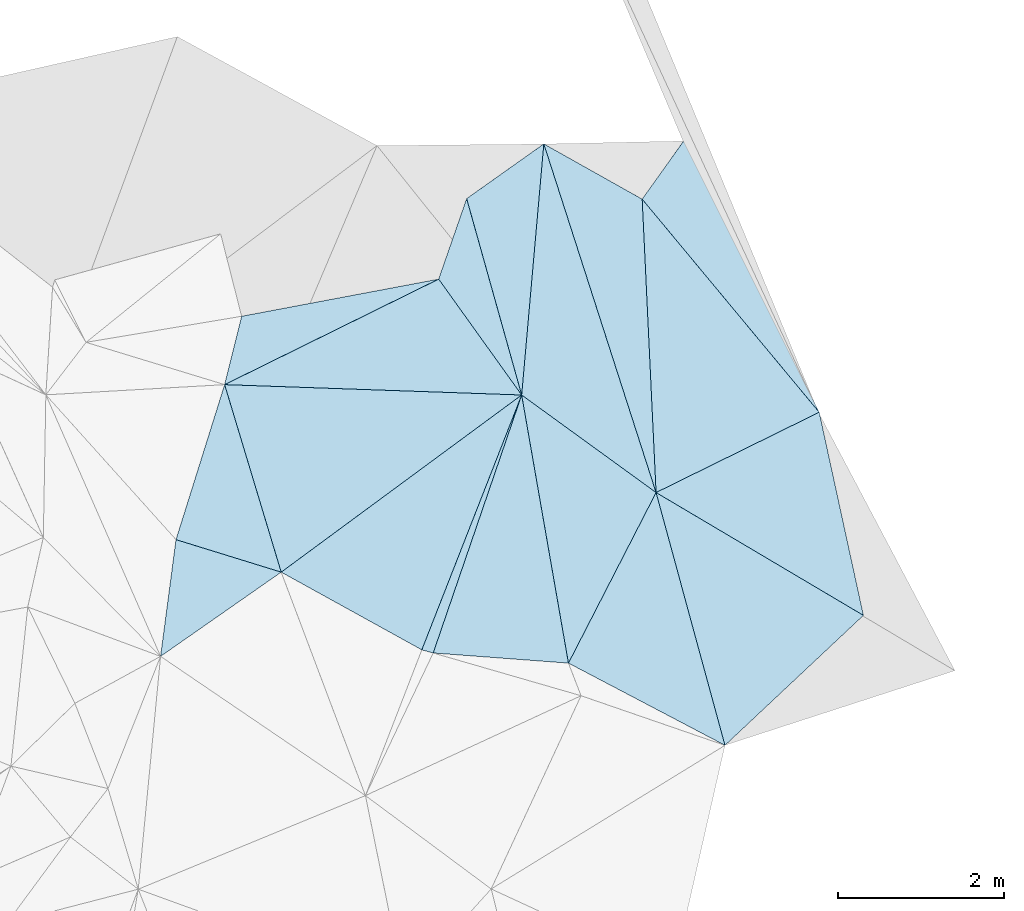
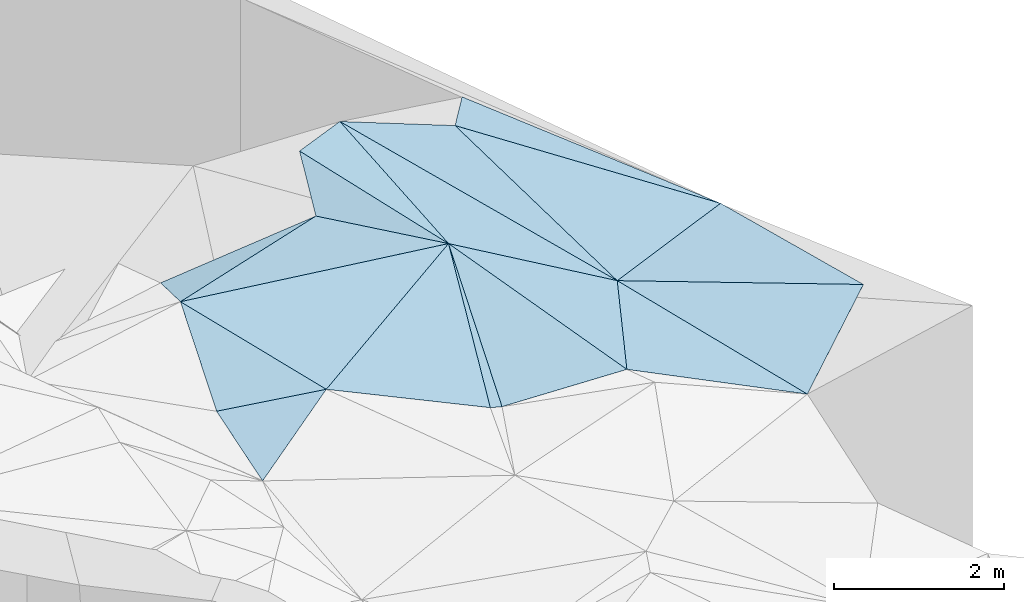
# One storey, part 163 of 275: 18 plates.
"""IFC2X3 building model written with IfcOpenShell, lengths in millimetres."""

from ifc_helpers import new_model, si_unit, frame, origin_with_axes, place, context, subcontext, project, spatial, polyline, outline, extrude, material, type_object, element, save


model = new_model("IFC2X3")

# Units and contexts
model_context = context("Model", 3, precision=1e-05, world=origin_with_axes())
body_context = subcontext(model_context, "Body", "Model", "MODEL_VIEW")
ifc_project = project(units=[si_unit("LENGTHUNIT", "METRE", prefix="MILLI"), si_unit("AREAUNIT", "SQUARE_METRE"), si_unit("VOLUMEUNIT", "CUBIC_METRE"), si_unit("MASSUNIT", "GRAM", prefix="KILO"), si_unit("TIMEUNIT", "SECOND"), si_unit("PLANEANGLEUNIT", "RADIAN"), si_unit("SOLIDANGLEUNIT", "STERADIAN"), si_unit("THERMODYNAMICTEMPERATUREUNIT", "DEGREE_CELSIUS"), si_unit("LUMINOUSINTENSITYUNIT", "LUMEN")], contexts=[model_context])

# Site, building, storey
site_placement = place(None, origin_with_axes())
site = spatial("IfcSite", under=ifc_project, at=site_placement, CompositionType="ELEMENT")
building_placement = place(site_placement, origin_with_axes())
building = spatial("IfcBuilding", under=site, at=building_placement, Name="Undefined", CompositionType="ELEMENT")
storey_placement = place(building_placement, origin_with_axes())
storey = spatial("IfcBuildingStorey", under=building, at=storey_placement, Name="Undefined", CompositionType="ELEMENT", Elevation=0.0)

# Plates
ifc_material = material()
plate_type_1 = type_object("IfcPlateType", PredefinedType="NOTDEFINED")
plate_1_placement = place(storey_placement, frame((-32198.8516801343, 135971.552970528, 45569.5074828096), z_axis=(-0.098591754816922, -0.141244502335463, -0.985053123664976), x_axis=(0.581396196965825, -0.811538201733318, 0.0581739570695312)))
element("IfcPlate", 1, at=plate_1_placement, inside=storey, type_object=plate_type_1, material=ifc_material, Name="00", context=body_context, shape_type="SweptSolid", body=[
    extrude(outline(polyline([(0.0, 0.0), (1718.98229980469, 9.60426405072212e-09), (-441.482147216797, 2872.2802734375), (0.0, 0.0)])), frame((-8.85201319254618e-08, 2.18876761149539e-07, -0.5000001331573), z_axis=(0.0, 0.0, 1.0), x_axis=(1.0, 0.0, 0.0)), (0.0, 0.0, 1.0), 1.0),
])
plate_type_2 = type_object("IfcPlateType", PredefinedType="NOTDEFINED")
plate_2_placement = place(storey_placement, frame((-31199.5191796899, 134576.589230725, 45669.5165076819), z_axis=(-0.253085129396398, -0.0291850272704862, -0.967003697749719), x_axis=(0.794519000365559, -0.57657067207497, -0.190540856933965)))
element("IfcPlate", 2, at=plate_2_placement, inside=storey, type_object=plate_type_2, material=ifc_material, Name="00", context=body_context, shape_type="SweptSolid", body=[
    extrude(outline(polyline([(0.0, 0.0), (2036.30871582031, -1.00117176771164e-08), (2318.16040039063, 2316.27563476563), (0.0, 0.0)])), frame((-8.85201319254618e-08, 2.18876761149539e-07, -0.5000001331573), z_axis=(0.0, 0.0, 1.0), x_axis=(1.0, 0.0, 0.0)), (0.0, 0.0, 1.0), 1.0),
])
plate_type_3 = type_object("IfcPlateType", PredefinedType="NOTDEFINED")
plate_3_placement = place(storey_placement, frame((-29581.5249611842, 133402.548021027, 45281.5007454787), z_axis=(-0.0365037972661945, 0.0401118083503274, -0.998528174673111), x_axis=(-0.306126815198871, 0.950709092130816, 0.0493821339757117)))
element("IfcPlate", 3, at=plate_3_placement, inside=storey, type_object=plate_type_3, material=ifc_material, Name="00", context=body_context, shape_type="SweptSolid", body=[
    extrude(outline(polyline([(0.0, 0.0), (4414.55224609375, 2.41725501837209e-08), (3416.37573242188, 923.422546386719), (0.0, 0.0)])), frame((-8.85201319254618e-08, 2.18876761149539e-07, -0.5000001331573), z_axis=(0.0, 0.0, 1.0), x_axis=(1.0, 0.0, 0.0)), (0.0, 0.0, 1.0), 1.0),
])
plate_type_4 = type_object("IfcPlateType", PredefinedType="NOTDEFINED")
plate_4_placement = place(storey_placement, frame((-31861.6968049564, 136940.684404504, 45799.5239126702), z_axis=(0.276526057594676, 0.129850128631399, -0.952193406596346), x_axis=(0.269448107091551, -0.961562111815432, -0.0528774309684792)))
element("IfcPlate", 4, at=plate_4_placement, inside=storey, type_object=plate_type_4, material=ifc_material, Name="00", context=body_context, shape_type="SweptSolid", body=[
    extrude(outline(polyline([(0.0, 0.0), (2458.51586914063, 1.18379830382764e-08), (853.116333007813, 614.485595703125), (0.0, 0.0)])), frame((-8.85201319254618e-08, 2.18876761149539e-07, -0.5000001331573), z_axis=(0.0, 0.0, 1.0), x_axis=(1.0, 0.0, 0.0)), (0.0, 0.0, 1.0), 1.0),
])
plate_type_5 = type_object("IfcPlateType", PredefinedType="NOTDEFINED")
plate_5_placement = place(storey_placement, frame((-34094.2186764133, 132444.009926367, 45879.5053858051), z_axis=(0.114175988951489, 0.0914077971950953, -0.989246409222136), x_axis=(-0.952143077843759, 0.294250805801101, -0.0827044291414697)))
element("IfcPlate", 5, at=plate_5_placement, inside=storey, type_object=plate_type_5, material=ifc_material, Name="00", context=body_context, shape_type="SweptSolid", body=[
    extrude(outline(polyline([(0.0, 0.0), (1330.03759765625, 5.355104804039e-09), (1301.84289550781, 1970.22973632813), (0.0, 0.0)])), frame((-8.85201319254618e-08, 2.18876761149539e-07, -0.5000001331573), z_axis=(0.0, 0.0, 1.0), x_axis=(1.0, 0.0, 0.0)), (0.0, 0.0, 1.0), 1.0),
])
plate_type_6 = type_object("IfcPlateType", PredefinedType="NOTDEFINED")
plate_6_placement = place(storey_placement, frame((-32198.7976080008, 135971.451329347, 45569.5306476429), z_axis=(0.00954903846279492, -0.344539341989418, -0.938723312635803), x_axis=(-0.88657658421872, -0.437100539241596, 0.151410299880072)))
element("IfcPlate", 6, at=plate_6_placement, inside=storey, type_object=plate_type_6, material=ifc_material, Name="00", context=body_context, shape_type="SweptSolid", body=[
    extrude(outline(polyline([(0.0, 0.0), (2906.01098632813, -1.42172211781144e-08), (2319.36499023438, 682.016418457031), (0.0, 0.0)])), frame((-8.85201319254618e-08, 2.18876761149539e-07, -0.5000001331573), z_axis=(0.0, 0.0, 1.0), x_axis=(1.0, 0.0, 0.0)), (0.0, 0.0, 1.0), 1.0),
])
plate_type_7 = type_object("IfcPlateType", PredefinedType="NOTDEFINED")
plate_7_placement = place(storey_placement, frame((-30636.1066323041, 131348.731635949, 45619.500279632), z_axis=(0.0260514513957656, 0.020027706044369, -0.999459960614118), x_axis=(-0.99690645753341, 0.0746849198356902, -0.0244883171599004)))
element("IfcPlate", 7, at=plate_7_placement, inside=storey, type_object=plate_type_7, material=ifc_material, Name="00", context=body_context, shape_type="SweptSolid", body=[
    extrude(outline(polyline([(0.0, 0.0), (1633.43200683594, -2.77941580861807e-09), (801.380187988281, 3177.54467773438), (0.0, 0.0)])), frame((-8.85201319254618e-08, 2.18876761149539e-07, -0.5000001331573), z_axis=(0.0, 0.0, 1.0), x_axis=(1.0, 0.0, 0.0)), (0.0, 0.0, 1.0), 1.0),
])
plate_type_8 = type_object("IfcPlateType", PredefinedType="NOTDEFINED")
plate_8_placement = place(storey_placement, frame((-32264.5281334498, 131470.738953015, 45579.5014925627), z_axis=(-0.0591918337237686, 0.0491899755037459, -0.9970339378027), x_axis=(-0.961535432290666, 0.265562617934711, 0.0701862408543488)))
element("IfcPlate", 8, at=plate_8_placement, inside=storey, type_object=plate_type_8, material=ifc_material, Name="00", context=body_context, shape_type="SweptSolid", body=[
    extrude(outline(polyline([(0.0, 0.0), (142.478073120117, 6.83940015733242e-10), (-193.012161254883, 3279.00073242188), (0.0, 0.0)])), frame((-8.85201319254618e-08, 2.18876761149539e-07, -0.5000001331573), z_axis=(0.0, 0.0, 1.0), x_axis=(1.0, 0.0, 0.0)), (0.0, 0.0, 1.0), 1.0),
])
plate_type_9 = type_object("IfcPlateType", PredefinedType="NOTDEFINED")
plate_9_placement = place(storey_placement, frame((-31199.4394425415, 134576.618369591, 45669.5024175395), z_axis=(-0.0936107219121646, 0.0290735471828012, -0.995184285244343), x_axis=(-0.80374358786138, -0.592112128062638, 0.0583049978376546)))
element("IfcPlate", 9, at=plate_9_placement, inside=storey, type_object=plate_type_9, material=ifc_material, Name="00", context=body_context, shape_type="SweptSolid", body=[
    extrude(outline(polyline([(0.0, 0.0), (3601.74951171875, -1.06228981167078e-09), (2819.962890625, 2228.31982421875), (0.0, 0.0)])), frame((-8.85201319254618e-08, 2.18876761149539e-07, -0.5000001331573), z_axis=(0.0, 0.0, 1.0), x_axis=(1.0, 0.0, 0.0)), (0.0, 0.0, 1.0), 1.0),
])
plate_type_10 = type_object("IfcPlateType", PredefinedType="NOTDEFINED")
plate_10_placement = place(storey_placement, frame((-34094.2253709488, 132443.987628679, 45879.5031058313), z_axis=(0.100785935198636, 0.0467981705699812, -0.993806885917702), x_axis=(-0.815037850956539, -0.568976419154106, -0.109449239169208)))
element("IfcPlate", 10, at=plate_10_placement, inside=storey, type_object=plate_type_10, material=ifc_material, Name="00", context=body_context, shape_type="SweptSolid", body=[
    extrude(outline(polyline([(0.0, 0.0), (1781.64782714844, -8.90577211976051e-09), (821.514770507813, 1045.99877929688), (0.0, 0.0)])), frame((-8.85201319254618e-08, 2.18876761149539e-07, -0.5000001331573), z_axis=(0.0, 0.0, 1.0), x_axis=(1.0, 0.0, 0.0)), (0.0, 0.0, 1.0), 1.0),
])
plate_type_11 = type_object("IfcPlateType", PredefinedType="NOTDEFINED")
plate_11_placement = place(storey_placement, frame((-30636.2369644922, 131348.701931195, 45619.514365859), z_axis=(-0.23462485257561, -0.0393693808402812, -0.971288438315893), x_axis=(0.451971642901497, 0.880192329887852, -0.144855432827062)))
element("IfcPlate", 11, at=plate_11_placement, inside=storey, type_object=plate_type_11, material=ifc_material, Name="00", context=body_context, shape_type="SweptSolid", body=[
    extrude(outline(polyline([(0.0, 0.0), (2333.36083984375, 1.087028067559e-08), (40.5299491882324, 2167.90234375), (0.0, 0.0)])), frame((-8.85201319254618e-08, 2.18876761149539e-07, -0.5000001331573), z_axis=(0.0, 0.0, 1.0), x_axis=(1.0, 0.0, 0.0)), (0.0, 0.0, 1.0), 1.0),
])
plate_type_12 = type_object("IfcPlateType", PredefinedType="NOTDEFINED")
plate_12_placement = place(storey_placement, frame((-31199.5371018139, 134576.589651607, 45669.5215468462), z_axis=(-0.288942134950096, -0.028344582871239, -0.956926866208874), x_axis=(-0.269448107032143, 0.961562111830375, 0.0528774309994816)))
element("IfcPlate", 12, at=plate_12_placement, inside=storey, type_object=plate_type_12, material=ifc_material, Name="00", context=body_context, shape_type="SweptSolid", body=[
    extrude(outline(polyline([(0.0, 0.0), (2458.51586914063, 1.18379830382764e-08), (2825.89599609375, 1118.935546875), (0.0, 0.0)])), frame((-8.85201319254618e-08, 2.18876761149539e-07, -0.5000001331573), z_axis=(0.0, 0.0, 1.0), x_axis=(1.0, 0.0, 0.0)), (0.0, 0.0, 1.0), 1.0),
])
plate_type_13 = type_object("IfcPlateType", PredefinedType="NOTDEFINED")
plate_13_placement = place(storey_placement, frame((-32401.5600212683, 131508.58907919, 45589.5055432495), z_axis=(-0.127553700477528, 0.0757638447575349, -0.988933715332855), x_axis=(-0.865580341192443, 0.478311033996727, 0.148287651873496)))
element("IfcPlate", 13, at=plate_13_placement, inside=storey, type_object=plate_type_13, material=ifc_material, Name="00", context=body_context, shape_type="SweptSolid", body=[
    extrude(outline(polyline([(0.0, 0.0), (1955.65844726563, 5.06406649947166e-09), (438.829193115234, 3266.77661132813), (0.0, 0.0)])), frame((-8.85201319254618e-08, 2.18876761149539e-07, -0.5000001331573), z_axis=(0.0, 0.0, 1.0), x_axis=(1.0, 0.0, 0.0)), (0.0, 0.0, 1.0), 1.0),
])
plate_type_14 = type_object("IfcPlateType", PredefinedType="NOTDEFINED")
plate_14_placement = place(storey_placement, frame((-29749.0290594562, 136934.398077426, 45429.5167602505), z_axis=(-0.242310486541354, -0.0848962471381377, -0.966477239946163), x_axis=(0.567560291417663, 0.795523035252382, -0.212175436817588)))
element("IfcPlate", 14, at=plate_14_placement, inside=storey, type_object=plate_type_14, material=ifc_material, Name="00", context=body_context, shape_type="SweptSolid", body=[
    extrude(outline(polyline([(0.0, 0.0), (881.346130371094, 7.78527464717627e-09), (-765.575500488281, 3260.73364257813), (0.0, 0.0)])), frame((-8.85201319254618e-08, 2.18876761149539e-07, -0.5000001331573), z_axis=(0.0, 0.0, 1.0), x_axis=(1.0, 0.0, 0.0)), (0.0, 0.0, 1.0), 1.0),
])
plate_type_15 = type_object("IfcPlateType", PredefinedType="NOTDEFINED")
plate_15_placement = place(storey_placement, frame((-27617.7017677399, 134369.160589362, 45120.5028330185), z_axis=(-0.0996992178638792, 0.0369407029665866, -0.994331660172633), x_axis=(-0.894790844875938, -0.440418190676039, 0.0733563988200696)))
element("IfcPlate", 15, at=plate_15_placement, inside=storey, type_object=plate_type_15, material=ifc_material, Name="00", context=body_context, shape_type="SweptSolid", body=[
    extrude(outline(polyline([(0.0, 0.0), (2194.76416015625, -9.70612745732069e-09), (799.891357421875, 3252.48559570313), (0.0, 0.0)])), frame((-8.85201319254618e-08, 2.18876761149539e-07, -0.5000001331573), z_axis=(0.0, 0.0, 1.0), x_axis=(1.0, 0.0, 0.0)), (0.0, 0.0, 1.0), 1.0),
])
plate_type_16 = type_object("IfcPlateType", PredefinedType="NOTDEFINED")
plate_16_placement = place(storey_placement, frame((-29581.5320689126, 133402.496253038, 45281.5016467235), z_axis=(-0.0504313865356066, -0.0635510515580077, -0.996703536212232), x_axis=(0.89479084487269, 0.440418190682357, -0.0733563988217526)))
element("IfcPlate", 16, at=plate_16_placement, inside=storey, type_object=plate_type_16, material=ifc_material, Name="00", context=body_context, shape_type="SweptSolid", body=[
    extrude(outline(polyline([(0.0, 0.0), (2194.76416015625, -9.70612745732069e-09), (1584.52868652344, 2430.75341796875), (0.0, 0.0)])), frame((-8.85201319254618e-08, 2.18876761149539e-07, -0.5000001331573), z_axis=(0.0, 0.0, 1.0), x_axis=(1.0, 0.0, 0.0)), (0.0, 0.0, 1.0), 1.0),
])
plate_type_17 = type_object("IfcPlateType", PredefinedType="NOTDEFINED")
plate_17_placement = place(storey_placement, frame((-30933.0470736582, 137599.466883924, 45499.5167785363), z_axis=(-0.254905690424387, -0.031879978514616, -0.966440249554609), x_axis=(0.306126815698584, -0.950709091969673, -0.0493821339802618)))
element("IfcPlate", 17, at=plate_17_placement, inside=storey, type_object=plate_type_17, material=ifc_material, Name="00", context=body_context, shape_type="SweptSolid", body=[
    extrude(outline(polyline([(0.0, 0.0), (4414.55224609375, 2.41725501837209e-08), (2783.90893554688, 1219.65405273438), (0.0, 0.0)])), frame((-8.85201319254618e-08, 2.18876761149539e-07, -0.5000001331573), z_axis=(0.0, 0.0, 1.0), x_axis=(1.0, 0.0, 0.0)), (0.0, 0.0, 1.0), 1.0),
])
plate_type_18 = type_object("IfcPlateType", PredefinedType="NOTDEFINED")
plate_18_placement = place(storey_placement, frame((-28752.0524616651, 130359.031117952, 45204.5001693287), z_axis=(0.00258756294426166, 0.0259962946071535, -0.999658690346214), x_axis=(-0.26286352476157, 0.964524390231099, 0.024402212999032)))
element("IfcPlate", 18, at=plate_18_placement, inside=storey, type_object=plate_type_18, material=ifc_material, Name="00", context=body_context, shape_type="SweptSolid", body=[
    extrude(outline(polyline([(0.0, 0.0), (3155.45141601563, -1.36897142510861e-08), (1072.00256347656, 2019.53796386719), (0.0, 0.0)])), frame((-8.85201319254618e-08, 2.18876761149539e-07, -0.5000001331573), z_axis=(0.0, 0.0, 1.0), x_axis=(1.0, 0.0, 0.0)), (0.0, 0.0, 1.0), 1.0),
])

save(model, "model.ifc")
